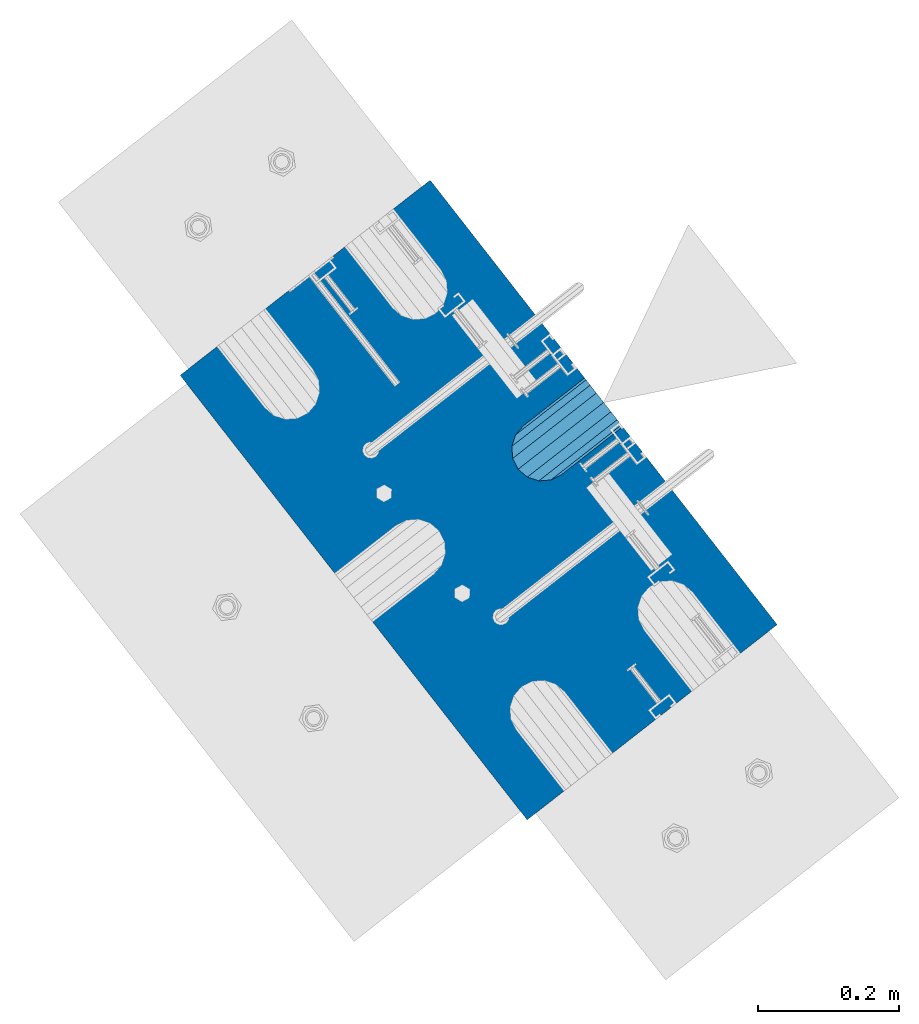
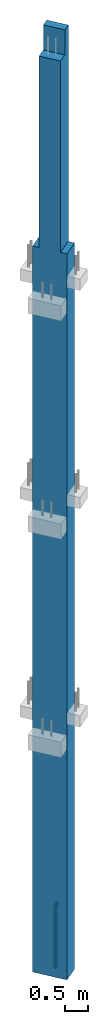
# One storey, part 2 of 42: 1 beam, 1 column, 2 elements without a shape of their own.
"""IFC2X3 building model written with IfcOpenShell, lengths in millimetres."""

import ifcopenshell
import ifcopenshell.guid

model = None  # the IFC model being written
_history = None  # IfcOwnerHistory: only IFC2X3 demands one
_inside = {}  # id of a spatial element -> (the spatial element, [elements in it])
_under = {}  # id of a project, library or spatial element -> (it, [spatial elements below it])
_declared = {}  # id of a project -> (the project, [libraries it declares])
_typed = {}  # id of a type object -> (the type object, [elements of that type])
_made_of = {}  # id of a material, layer set ... -> (it, [elements and type objects made of it])


def new_model(schema):
    """Start an empty IFC model of exactly this schema.

    Asked for "IFC4X3", IfcOpenShell would pick the latest addendum, in which some entities
    have other attributes; the version numbers below select the first issue.
    IFC2X3 requires an IfcOwnerHistory on every rooted entity: one is made here for all.
    """
    global model, _history
    if schema == "IFC4X3":
        model = ifcopenshell.file(schema_version=(4, 3, 0, 0))
    else:
        model = ifcopenshell.file(schema=schema)
    _inside.clear()
    _under.clear()
    _declared.clear()
    _typed.clear()
    _made_of.clear()
    _history = None
    if model.schema == "IFC2X3":
        org = make("IfcOrganization", Name="unknown")
        user = make(
            "IfcPersonAndOrganization",
            ThePerson=make("IfcPerson", FamilyName="unknown"),
            TheOrganization=org,
        )
        app = make(
            "IfcApplication",
            ApplicationDeveloper=org,
            Version="unknown",
            ApplicationFullName="unknown",
            ApplicationIdentifier="unknown",
        )
        _history = make(
            "IfcOwnerHistory",
            OwningUser=user,
            OwningApplication=app,
            ChangeAction="ADDED",
            CreationDate=0,
        )
    return model


def make(cls, **values):
    """One entity of the class cls with the attributes given. An attribute that is None is left unset."""
    return model.create_entity(
        cls, **{name: value for name, value in values.items() if value is not None}
    )


def rooted(cls, **values):
    """An entity with a GlobalId (a new one), such as an element, a storey or a relation."""
    return make(cls, GlobalId=ifcopenshell.guid.new(), OwnerHistory=_history, **values)


def si_unit(unit_type, name, prefix=None):
    """IfcSIUnit, for example si_unit("LENGTHUNIT", "METRE", prefix="MILLI")."""
    return make("IfcSIUnit", UnitType=unit_type, Prefix=prefix, Name=name)


def assignment(units):
    """IfcUnitAssignment: the units of a project."""
    return None if units is None else make("IfcUnitAssignment", Units=units)


def point(xyz):
    """IfcCartesianPoint."""
    return None if xyz is None else make("IfcCartesianPoint", Coordinates=xyz)


def direction(xyz):
    """IfcDirection."""
    return None if xyz is None else make("IfcDirection", DirectionRatios=xyz)


def frame(location, z_axis=None, x_axis=None):
    """IfcAxis2Placement3D, a coordinate frame: its origin and axes. An axis left out is left unset."""
    return make(
        "IfcAxis2Placement3D",
        Location=point(location),
        Axis=direction(z_axis),
        RefDirection=direction(x_axis),
    )


def origin_with_axes():
    """The frame at (0, 0, 0) with the z axis (0, 0, 1) and the x axis (1, 0, 0) written out."""
    return frame((0.0, 0.0, 0.0), z_axis=(0.0, 0.0, 1.0), x_axis=(1.0, 0.0, 0.0))


def place(relative_to, where):
    """IfcLocalPlacement: puts the frame where relative to a parent placement (None: the world)."""
    return make(
        "IfcLocalPlacement", PlacementRelTo=relative_to, RelativePlacement=where
    )


def context(
    kind, dimensions, precision=None, world=None, true_north=None, identifier=None
):
    """IfcGeometricRepresentationContext, for example the 3D "Model" context."""
    return make(
        "IfcGeometricRepresentationContext",
        ContextIdentifier=identifier,
        ContextType=kind,
        CoordinateSpaceDimension=dimensions,
        Precision=precision,
        WorldCoordinateSystem=world,
        TrueNorth=true_north,
    )


def subcontext(parent, identifier, kind, view, scale=None):
    """IfcGeometricRepresentationSubContext, for example "Body" below "Model"."""
    return make(
        "IfcGeometricRepresentationSubContext",
        ContextIdentifier=identifier,
        ContextType=kind,
        ParentContext=parent,
        TargetScale=scale,
        TargetView=view,
    )


def project(units=None, contexts=None):
    """IfcProject with its units and contexts."""
    return rooted(
        "IfcProject",
        Name="project",
        RepresentationContexts=contexts,
        UnitsInContext=assignment(units),
    )


def spatial(cls, under=None, at=None, **own):
    """A site, building, storey or space (cls), placed at a placement, below another one or the project."""
    s = rooted(cls, ObjectPlacement=at, **own)
    if under is not None:
        _under.setdefault(under.id(), (under, []))[1].append(s)
    return s


def faces_of(points, faces, orient=None, outer=None):
    """IfcFace entities. A face is a list of loops; a loop is a list of indices into points, from 0.

    orient and outer hold one flag for each loop. By default every Orientation is true, the
    first loop of a face is its IfcFaceOuterBound and the others are IfcFaceBound.
    """
    made = []
    for i, loops in enumerate(faces):
        bounds = []
        for j, loop in enumerate(loops):
            is_outer = j == 0 if outer is None else outer[i][j]
            bounds.append(
                make(
                    "IfcFaceOuterBound" if is_outer else "IfcFaceBound",
                    Bound=make("IfcPolyLoop", Polygon=[points[k] for k in loop]),
                    Orientation=True if orient is None else orient[i][j],
                )
            )
        made.append(make("IfcFace", Bounds=bounds))
    return made


def faceted_brep(points, faces, orient=None, outer=None, voids=None):
    """IfcFacetedBrep: a solid bounded by flat faces; with voids (closed shells), ...WithVoids."""
    shared = [point(p) for p in points]
    hull = make("IfcClosedShell", CfsFaces=faces_of(shared, faces, orient, outer))
    if voids is None:
        return make("IfcFacetedBrep", Outer=hull)
    return make(
        "IfcFacetedBrepWithVoids",
        Outer=hull,
        Voids=[
            make(cls, CfsFaces=faces_of(shared, fs, o, b)) for cls, fs, o, b in voids
        ],
    )


def shape(context_of_items, identifier, shape_type, items):
    """IfcShapeRepresentation: the items that make up one representation, for example the "Body"."""
    return make(
        "IfcShapeRepresentation",
        ContextOfItems=context_of_items,
        RepresentationIdentifier=identifier,
        RepresentationType=shape_type,
        Items=items,
    )


def material(Name=None, Category=None):
    """IfcMaterial."""
    return make("IfcMaterial", Name=Name, Category=Category)


def made_of(thing, what):
    """Note that an element or type object is made of a material, layer set ...; save() writes the relation."""
    if what is not None:
        _made_of.setdefault(what.id(), (what, []))[1].append(thing)
    return thing


def type_object(cls, material=None, **own):
    """A type object (cls), such as IfcWallType, which elements share."""
    return made_of(rooted(cls, **own), material)


def element(
    cls,
    number,
    at=None,
    inside=None,
    cuts=None,
    type_object=None,
    material=None,
    context=None,
    identifier="Body",
    shape_type=None,
    held_by="IfcProductDefinitionShape",
    body=None,
    shapes=None,
    **own,
):
    """One element of the class cls, such as IfcWall. Its Tag is "e" and its number.

    at: its placement. inside: the storey or other place that contains it. cuts: it is an
    opening in that element (IfcRelVoidsElement). A single representation is given by context,
    identifier, shape_type and body (its items); several are given by shapes. held_by: the class
    of the entity that holds the representations. save() writes the other relations.
    """
    e = rooted(cls, Tag="e%d" % number, ObjectPlacement=at, **own)
    if body is not None:
        shapes = [shape(context, identifier, shape_type, body)]
    if shapes is not None:
        e.Representation = make(held_by, Representations=shapes)
    if inside is not None:
        _inside.setdefault(inside.id(), (inside, []))[1].append(e)
    if cuts is not None:
        rooted(
            "IfcRelVoidsElement", RelatingBuildingElement=cuts, RelatedOpeningElement=e
        )
    if type_object is not None:
        _typed.setdefault(type_object.id(), (type_object, []))[1].append(e)
    return made_of(e, material)


def aggregate(whole, parts):
    """IfcRelAggregates: a whole, such as a stair, and the parts it consists of."""
    return rooted("IfcRelAggregates", RelatingObject=whole, RelatedObjects=parts)


def save(model, path):
    """Write the relations noted so far, then the file.

    IfcRelAggregates (storeys below a building ...), IfcRelContainedInSpatialStructure (elements
    in a storey), IfcRelDefinesByType, IfcRelAssociatesMaterial and IfcRelDeclares: one each for
    every whole, place, type object, material and project.
    """
    for whole, parts in _under.values():
        aggregate(whole, parts)
    for where, things in _inside.values():
        rooted(
            "IfcRelContainedInSpatialStructure",
            RelatedElements=things,
            RelatingStructure=where,
        )
    for kind, things in _typed.values():
        rooted("IfcRelDefinesByType", RelatedObjects=things, RelatingType=kind)
    for what, things in _made_of.values():
        rooted("IfcRelAssociatesMaterial", RelatedObjects=things, RelatingMaterial=what)
    for by, libraries in _declared.values():
        rooted("IfcRelDeclares", RelatingContext=by, RelatedDefinitions=libraries)
    model.write(path)


model = new_model("IFC2X3")

# Units and contexts
model_context = context("Model", 3, precision=1e-05, world=origin_with_axes())
body_context = subcontext(model_context, "Body", "Model", "MODEL_VIEW")
ifc_project = project(units=[si_unit("LENGTHUNIT", "METRE", prefix="MILLI"), si_unit("AREAUNIT", "SQUARE_METRE"), si_unit("VOLUMEUNIT", "CUBIC_METRE"), si_unit("MASSUNIT", "GRAM", prefix="KILO"), si_unit("TIMEUNIT", "SECOND"), si_unit("PLANEANGLEUNIT", "RADIAN"), si_unit("SOLIDANGLEUNIT", "STERADIAN"), si_unit("THERMODYNAMICTEMPERATUREUNIT", "DEGREE_CELSIUS"), si_unit("LUMINOUSINTENSITYUNIT", "LUMEN")], contexts=[model_context])

# Site, building, storey
site_placement = place(None, frame((171687.4, 84828.52, 14700.0), z_axis=(0.0, 0.0, 1.0), x_axis=(1.0, 0.0, 0.0)))
site = spatial("IfcSite", under=ifc_project, at=site_placement, CompositionType="ELEMENT")
building_placement = place(site_placement, origin_with_axes())
building = spatial("IfcBuilding", under=site, at=building_placement, Name="Undefined", CompositionType="ELEMENT")
storey_placement = place(building_placement, origin_with_axes())
storey = spatial("IfcBuildingStorey", under=building, at=storey_placement, Name="Undefined", CompositionType="ELEMENT", Elevation=0.0)

# Assemblies, column, beam
assembly_1_placement = place(storey_placement, origin_with_axes())
assembly_1 = element("IfcElementAssembly", 1, at=assembly_1_placement, inside=storey, AssemblyPlace="NOTDEFINED", PredefinedType="REINFORCEMENT_UNIT")
ifc_material_1 = material(Name="CONCRETE/C50/60")
column_type = type_object("IfcColumnType", PredefinedType="NOTDEFINED")
column_placement = place(assembly_1_placement, frame((18096.7856708698, 265349.288407257, -1290.0), z_axis=(-0.788225611989142, -0.615386370180835, 0.0), x_axis=(0.0, 0.0, 1.0)))
column = element("IfcColumn", 2, at=column_placement, type_object=column_type, material=ifc_material_1, context=body_context, shape_type="Brep", body=[
    faceted_brep([(24210.0, -250.000000288157, 225.00000024747), (24210.0, -250.000000288797, -24.9999997523264), (24210.0, 249.99999971097, -24.9999997548875), (24210.0, 249.999999711639, 225.000000244938), (24870.0, -250.000000288797, -24.9999997523264), (24870.0, 249.99999971097, -24.9999997548875), (19160.0, -400.000000288099, 225.000000248256), (19160.0, -400.000000289263, -224.999999751424), (19160.0, -250.000000289321, -224.999999752152), (19160.0, -250.000000288157, 225.00000024747), (0.0, -400.000000329339, 225.000000121712), (0.0, -400.000000330474, -224.999999877968), (0.0, 399.999999670341, 225.000000117609), (0.0, 399.999999669206, -224.999999882071), (19160.0, 399.999999711552, 225.000000244181), (19160.0, 399.999999710388, -224.999999755499), (19160.0, 249.999999711639, 225.000000244938), (19160.0, 249.999999710475, -224.999999754713), (24870.0, -250.000000289321, -224.999999752152), (24870.0, 249.999999710475, -224.999999754713)], [[[0, 1, 2, 3]], [[4, 5, 2, 1]], [[6, 7, 8, 9]], [[10, 11, 7, 6]], [[11, 10, 12, 13]], [[13, 12, 14, 15]], [[16, 17, 15, 14]], [[18, 8, 7, 11, 13, 15, 17, 19]], [[0, 9, 8, 18, 4, 1]], [[16, 14, 12, 10, 6, 9, 0, 3]], [[19, 17, 16, 3, 2, 5]], [[18, 19, 5, 4]]]),
])
assembly_2_placement = place(assembly_1_placement, origin_with_axes())
assembly_2 = element("IfcElementAssembly", 3, at=assembly_2_placement, AssemblyPlace="NOTDEFINED", PredefinedType="RIGID_FRAME")
aggregate(assembly_1, [assembly_2, column])
ifc_material_2 = material(Name="STEEL/NEG_BETON")
beam_type = type_object("IfcBeamType", PredefinedType="NOTDEFINED")
beam_placement = place(assembly_2_placement, frame((18187.4316162484, 265420.057839827, -1290.0), z_axis=(0.615386370178831, -0.788225611990706, 0.0), x_axis=(0.0, 0.0, 1.0)))
beam = element("IfcBeam", 4, at=beam_placement, type_object=beam_type, material=ifc_material_2, context=body_context, shape_type="Brep", body=[
    faceted_brep([(0.0, -43.999999753345, 2.88331648334861e-07), (0.0, -40.6506991838105, -16.8380707357428), (1590.0, -40.6506991838105, -16.8380707357428), (1589.99999999999, -43.999999753345, 2.88331648334861e-07), (0.0, -31.1126981254783, -31.1126980838017), (1590.0, -31.1126981254783, -31.1126980838017), (0.0, -16.8380707773322, -40.6506991419883), (1590.0, -16.8380707773322, -40.6506991419883), (0.0, 2.46742274612188e-07, -43.9999997114064), (1590.0, 2.46742274612188e-07, -43.9999997114064), (0.0, 16.8380712707876, -40.6506991418137), (1590.0, 16.8380712707876, -40.6506991418137), (0.0, 31.1126986189047, -31.1126980834524), (1590.0, 31.1126986189047, -31.1126980834524), (0.0, 40.6506996771204, -16.8380707352771), (1590.0, 40.6506996771204, -16.8380707352771), (0.0, 44.0000002465677, 2.88768205791712e-07), (1590.0, 44.0000002465677, 2.88768205791712e-07), (0.0, 40.6506996770622, 16.8380713128427), (1590.0, 40.6506996770622, 16.8380713128427), (0.0, 31.1126986187301, 31.1126986609306), (1590.0, 31.1126986187301, 31.1126986609306), (0.0, 16.8380712705839, 40.6506997191464), (1590.0, 16.8380712705839, 40.6506997191464), (0.0, 2.46509443968534e-07, 44.0000002885354), (1590.0, 2.46509443968534e-07, 44.0000002885354), (0.0, -16.8380707775359, 40.6506997189426), (1590.0, -16.8380707775359, 40.6506997189426), (0.0, -31.1126981256821, 31.1126986605814), (1590.0, -31.1126981256821, 31.1126986605814), (0.0, -40.6506991838978, 16.838071312377), (1590.0, -40.6506991838978, 16.838071312377), (4.47878846898675e-07, -40.0000000634464, 0.0), (4.47878846898675e-07, -36.9551813638827, 15.3073372946019), (1590.0, -36.9551810538396, 15.3073375829845), (1589.99999999999, -39.999999753345, 2.88360752165318e-07), (4.47937054559588e-07, -28.2842713108694, 28.284271247463), (1590.0, -28.2842710008845, 28.2842715359002), (4.4800981413573e-07, -15.3073373580119, 36.9551813004509), (1590.0, -15.3073370480561, 36.9551815889135), (4.48068021796644e-07, -6.34463503956795e-08, 40.0), (1590.0, 2.46538547798991e-07, 40.0000002885645), (4.48140781372786e-07, 15.3073372311774, 36.9551813004509), (1590.0, 15.3073375411332, 36.9551815890882), (4.48213540948927e-07, 28.2842711840058, 28.284271247463), (1590.0, 28.2842714939907, 28.2842715361621), (4.48271748609841e-07, 36.95518123699, 15.3073372946019), (1590.0, 36.9551815469749, 15.3073375833046), (4.48286300525069e-07, 39.9999999365536, 0.0), (1590.0, 40.0000002465677, 2.88768205791712e-07), (4.48271748609841e-07, 36.95518123699, -15.3073372946019), (1590.0, 36.9551815470913, -15.3073370058555), (4.48213540948927e-07, 28.2842711840058, -28.284271247463), (1590.0, 28.2842714941071, -28.2842709587712), (4.48140781372786e-07, 15.3073372311774, -36.9551813004509), (1590.0, 15.3073375413369, -36.9551810117846), (4.48068021796644e-07, -6.34463503956795e-08, -40.0), (1590.0, 2.46742274612188e-07, -39.9999997114064), (4.4800981413573e-07, -15.3073373580119, -36.9551813004509), (1590.0, -15.3073370479106, -36.9551810119592), (4.47937054559588e-07, -28.2842713108694, -28.284271247463), (1590.0, -28.284271000739, -28.2842709590332), (4.47878846898675e-07, -36.9551813638827, -15.3073372946019), (1590.0, -36.9551810537523, -15.3073370062048), (1591.55291427061, -44.204444795876, 2.88884621113539e-07), (1592.41977704577, -40.969268875866, 16.83807131293), (1594.88839337186, -31.7562673225475, 31.1126986611343), (1598.5829387913, -17.9680361063511, 40.6506997194665), (1602.94095225512, -1.70370843930868, 44.0000002890592), (1607.29896571893, 14.5606192276464, 40.650699719612), (1610.99351113838, 28.3488504439301, 31.1126986614254), (1613.46212746447, 37.5618519973068, 16.8380713133374), (1614.32899023963, 40.7970279174624, 2.89292074739933e-07), (1613.46212746447, 37.5618519973941, -16.8380707347824), (1610.99351113838, 28.3488504441048, -31.1126980829576), (1607.29896571893, 14.5606192278792, -40.650699141348), (1602.94095225512, -1.70370843910496, -43.9999997109117), (1598.5829387913, -17.9680361061473, -40.6506991414644), (1594.88839337186, -31.7562673223438, -31.1126980832487), (1592.41977704577, -40.9692688757787, -16.8380707351898), (1613.29371405922, 36.9333246122987, 2.89292074739933e-07), (1612.50565699089, 33.9922555939993, 15.3073375838285), (1610.26146033081, 25.6167996363656, 28.2842715366569), (1606.90278267677, 13.082043985225, 36.9551815895829), (1602.94095225512, -1.70370843933779, 40.0000002890883), (1598.97912183347, -16.4894608639006, 36.9551815894083), (1595.62044417943, -29.024216514983, 28.2842715363658), (1593.37624751934, -37.3996724725293, 15.3073375835083), (1592.58819045102, -40.3407414907415, 2.88913724943995e-07), (1593.37624751934, -37.3996724724711, -15.30733700571), (1595.62044417943, -29.0242165148375, -28.2842709585093), (1598.97912183347, -16.489460863726, -36.9551810114353), (1602.94095225512, -1.70370843910496, -39.9999997108825), (1606.90278267677, 13.0820439854288, -36.9551810112898), (1610.26146033081, 25.6167996365111, -28.2842709582183), (1612.50565699089, 33.9922555940866, -15.3073370053316), (1630.55634918609, 20.2456576060504, 31.1126986613672), (1635.32534971523, 28.5058088238875, 16.8380713132792), (1623.41903551202, 7.88346769296913, 40.6506997195829), (1614.99999999998, -6.6987295645813, 44.0000002890592), (1606.58096448795, -21.2809268221026, 40.6506997194665), (1599.44365081388, -33.6431167351257, 31.1126986611052), (1594.67465028474, -41.9032679528755, 16.83807131293), (1592.99999999999, -44.8038473309425, 2.88884621113539e-07), (1594.67465028474, -41.9032679528173, -16.8380707351898), (1599.44365081388, -33.6431167349801, -31.1126980832778), (1606.58096448795, -21.2809268218698, -40.6506991414935), (1614.99999999998, -6.69872956431936, -43.9999997108825), (1623.41903551202, 7.88346769317286, -40.6506991413771), (1630.55634918609, 20.245657606225, -31.1126980830159), (1635.32534971523, 28.5058088239748, -16.8380707348406), (1636.99999999998, 31.4063882019836, 2.89204763248563e-07), (1633.47759065021, 25.3053962432023, -15.307337005419), (1634.99999999998, 27.9422865869128, 2.89262970909476e-07), (1629.14213562371, 17.7961678634456, -28.2842709582474), (1622.65366864729, 6.55781339702662, -36.9551810113189), (1614.99999999998, -6.69872956431936, -39.9999997109117), (1607.34633135268, -19.9552725257818, -36.9551810114644), (1600.85786437626, -31.1936269922007, -28.2842709585384), (1596.52240934976, -38.7028553720447, -15.30733700571), (1594.99999999999, -41.3397457158135, 2.88884621113539e-07), (1596.52240934976, -38.7028553721029, 15.3073375835083), (1600.85786437626, -31.1936269923463, 28.2842715363658), (1607.34633135268, -19.9552725259855, 36.9551815894083), (1614.99999999998, -6.6987295645522, 40.0000002890592), (1622.65366864729, 6.5578133968811, 36.9551815895829), (1629.14213562371, 17.796167863271, 28.2842715366278), (1633.47759065021, 25.305396243115, 15.3073375837994), (1647.35533905931, 7.35533930556267, 31.1126986613381), (1654.09972428659, 14.0997245328326, 16.8380713131919), (1637.26165326253, -2.73834649124183, 40.6506997195538), (1625.35533905931, -14.6446606944664, 44.000000289001), (1613.4490248561, -26.5509748976619, 40.6506997194374), (1603.35533905931, -36.6446606944373, 31.1126986610761), (1596.61095383203, -43.3890459216491, 16.83807131293), (1594.24264068711, -45.7573590665124, 2.88855517283082e-07), (1596.61095383203, -43.3890459215909, -16.8380707352189), (1603.35533905931, -36.6446606942627, -31.1126980833069), (1613.4490248561, -26.5509748974582, -40.6506991415517), (1625.35533905931, -14.6446606942336, -43.9999997109699), (1637.26165326253, -2.7383464910381, -40.6506991414062), (1647.35533905931, 7.35533930567908, -31.1126980831032), (1654.09972428659, 14.099724532949, -16.8380707348988), (1656.46803743151, 16.4680376778415, 2.89175659418106e-07), (1651.48659835683, 11.4865986031655, -15.3073370054772), (1653.63961030677, 13.6396105530439, 2.89146555587649e-07), (1645.35533905931, 5.35533930567908, -28.2842709583347), (1636.17926106223, -3.82073869134183, -36.9551810113771), (1625.35533905931, -14.6446606942336, -39.9999997109699), (1614.53141705639, -25.4685826971836, -36.9551810114644), (1605.35533905931, -34.6446606942627, -28.2842709585675), (1599.22407976179, -40.7759199918073, -15.3073370057391), (1597.07106781185, -42.9289319418021, 2.88826413452625e-07), (1599.22407976179, -40.7759199918946, 15.3073375834792), (1605.35533905931, -34.6446606944082, 28.284271536395), (1614.53141705639, -25.4685826973582, 36.9551815894083), (1625.35533905931, -14.6446606944373, 40.000000289001), (1636.17926106223, -3.82073869154556, 36.9551815894956), (1645.35533905931, 5.35533930556267, 28.2842715365696), (1651.48659835683, 11.4865986031364, 15.3073375837412), (1660.24565735981, -9.44365056764218, 31.1126986612508), (1668.50580857761, -4.6746500384761, 16.8380713131337), (1647.88346744676, -16.5809642417589, 40.6506997194665), (1633.3012701892, -24.9999997537816, 44.0000002889428), (1618.71907293164, -33.4190352658043, 40.6506997193792), (1606.35688301859, -40.5563489398628, 31.112698661047), (1598.09673180079, -45.3253494689416, 16.8380713129009), (1595.19615242269, -46.9999997536361, 2.88855517283082e-07), (1598.09673180079, -45.3253494688834, -16.8380707352189), (1606.35688301859, -40.5563489396882, -31.112698083336), (1618.71907293164, -33.4190352655714, -40.6506991415517), (1633.3012701892, -24.9999997535488, -43.9999997110281), (1647.88346744676, -16.5809642415552, -40.6506991414644), (1660.24565735981, -9.44365056749666, -31.1126980831614), (1668.50580857761, -4.67465003841789, -16.8380707349861), (1671.40638795571, -2.99999975369428, 2.89088347926736e-07), (1665.30539599684, -6.52240910343244, -15.3073370055354), (1667.94228634057, -4.99999975372339, 2.89030140265822e-07), (1657.79616761703, -10.8578641298518, -28.2842709583929), (1646.55781315062, -17.3463311062951, -36.9551810114644), (1633.3012701892, -24.9999997535488, -39.999999710999), (1620.04472722778, -32.6536684008606, -36.9551810115227), (1608.80637276137, -39.142135377333, -28.2842709585675), (1601.29714438156, -43.4775904038397, -15.30733700571), (1598.66025403783, -44.9999997536652, 2.88826413452625e-07), (1601.29714438156, -43.4775904038979, 15.3073375834501), (1608.80637276137, -39.1421353774786, 28.2842715363076), (1620.04472722778, -32.6536684010644, 36.9551815893792), (1633.3012701892, -24.9999997537816, 40.0000002889428), (1646.55781315062, -17.3463311064697, 36.9551815894374), (1657.79616761703, -10.8578641300264, 28.2842715364823), (1665.30539599684, -6.52240910349065, 15.3073375836248), (1668.34885019768, -29.006488615385, 31.1126986611052), (1677.56185175105, -26.5378722892492, 16.8380713130173), (1654.56061898146, -32.7010340348643, 40.6506997193792), (1638.29629131443, -37.0590474986238, 44.0000002888846), (1622.0319636474, -41.4170609624416, 40.6506997193792), (1608.24373243118, -45.1116063818336, 31.1126986610761), (1599.03073087781, -47.5802227078821, 16.83807131293), (1595.79555495772, -48.4470854829997, 2.88855517283082e-07), (1599.03073087781, -47.5802227078239, -16.8380707351898), (1608.24373243118, -45.111606381688, -31.112698083336), (1622.0319636474, -41.4170609622379, -40.6506991415808), (1638.29629131443, -37.0590474984201, -43.9999997110572), (1654.56061898146, -32.7010340346314, -40.6506991415808), (1668.34885019768, -29.0064886152395, -31.1126980832778), (1677.56185175105, -26.5378722891619, -16.8380707351025), (1680.79702767114, -25.6710095140443, 2.88913724943995e-07), (1673.99225534772, -27.4943427627441, -15.3073370056518), (1676.93332436598, -26.7062856944685, 2.88942828774452e-07), (1665.61679939011, -29.7385394227749, -28.2842709585093), (1653.082043739, -33.0972170768073, -36.9551810115518), (1638.29629131443, -37.0590474984201, -39.9999997110572), (1623.51053888986, -41.020877920062, -36.9551810115518), (1610.97578323875, -44.3795555741235, -28.2842709585675), (1602.60032728114, -46.6237522342417, -15.3073370057391), (1599.65925826287, -47.4118093026336, 2.88826413452625e-07), (1602.60032728114, -46.623752234329, 15.3073375834501), (1610.97578323875, -44.379555574269, 28.2842715363076), (1623.51053888986, -41.0208779202658, 36.955181589321), (1638.29629131443, -37.0590474986238, 40.0000002889137), (1653.082043739, -33.0972170769819, 36.9551815893501), (1665.61679939011, -29.7385394229495, 28.2842715363658), (1673.99225534772, -27.4943427628314, 15.3073375835083), (1608.88730162777, -49.9999997535779, -31.1126980833942), (1599.34930056949, -49.999999753607, -16.838070735248), (1623.16192897591, -49.9999997535488, -40.6506991416682), (1639.99999999997, -49.9999997535488, -43.9999997111445), (1656.83807102403, -49.9999997535488, -40.6506991416682), (1671.11269837217, -49.9999997535779, -31.1126980833942), (1680.65069943045, -49.999999753607, -16.838070735248), (1683.99999999996, -49.9999997536361, 2.88826413452625e-07), (1680.65069943045, -49.9999997536943, 16.8380713128718), (1671.11269837217, -49.9999997537234, 31.1126986609888), (1656.83807102403, -49.9999997537525, 40.650699719321), (1639.99999999997, -49.9999997537816, 44.0000002887973), (1623.16192897591, -49.9999997537525, 40.650699719321), (1608.88730162777, -49.9999997536943, 31.112698661047), (1599.34930056949, -49.9999997536943, 16.8380713128718), (1596.0, -49.9999997536361, 2.88826413452625e-07), (1676.95518130041, -49.9999997535779, -15.3073370057391), (1679.99999999996, -49.9999997536361, 2.88826413452625e-07), (1668.28427124742, -49.9999997535488, -28.2842709585966), (1655.30733729457, -49.9999997535488, -36.9551810116391), (1639.99999999997, -49.9999997535197, -39.9999997111445), (1624.69266270537, -49.9999997535488, -36.9551810116391), (1611.71572875252, -49.9999997535488, -28.2842709585966), (1603.04481869953, -49.9999997535779, -15.3073370057391), (1600.0, -49.9999997536361, 2.88826413452625e-07), (1603.04481869953, -49.9999997536943, 15.307337583421), (1611.71572875252, -49.9999997537234, 28.2842715362785), (1624.69266270537, -49.9999997537525, 36.9551815892628), (1639.99999999997, -49.9999997537525, 40.0000002888264), (1655.30733729457, -49.9999997537525, 36.9551815892628), (1668.28427124742, -49.9999997537234, 28.2842715362785), (1676.95518130041, -49.9999997536943, 15.307337583421), (1599.3493005695, -109.999999753578, -16.8380707355391), (1596.0, -109.999999753607, 2.88506271317601e-07), (1608.88730162779, -109.999999753549, -31.1126980836852), (1623.16192897594, -109.999999753491, -40.6506991419592), (1640.0, -109.999999753491, -43.9999997114646), (1656.83807102406, -109.999999753491, -40.6506991419592), (1671.11269837221, -109.999999753549, -31.1126980836852), (1680.6506994305, -109.999999753578, -16.8380707355391), (1684.0, -109.999999753607, 2.88506271317601e-07), (1680.6506994305, -109.999999753636, 16.8380713125807), (1671.11269837221, -109.999999753694, 31.1126986607269), (1656.83807102406, -109.999999753723, 40.6506997190008), (1640.0, -109.999999753723, 44.0000002885063), (1623.16192897594, -109.999999753723, 40.6506997190008), (1608.88730162779, -109.999999753694, 31.1126986607269), (1599.3493005695, -109.999999753636, 16.8380713125807), (1603.04481869955, -109.999999753636, 15.3073375831009), (1600.0, -109.999999753607, 2.88506271317601e-07), (1611.71572875254, -109.999999753665, 28.2842715359584), (1624.6926627054, -109.999999753665, 36.9551815889718), (1640.0, -109.999999753694, 40.0000002884772), (1655.3073372946, -109.999999753665, 36.9551815889718), (1668.28427124746, -109.999999753665, 28.2842715359584), (1676.95518130045, -109.999999753636, 15.3073375831009), (1680.0, -109.999999753607, 2.88506271317601e-07), (1676.95518130045, -109.999999753578, -15.3073370060883), (1668.28427124746, -109.999999753549, -28.2842709589167), (1655.3073372946, -109.99999975352, -36.955181011901), (1640.0, -109.99999975352, -39.9999997114646), (1624.6926627054, -109.99999975352, -36.955181011901), (1611.71572875254, -109.999999753549, -28.2842709589167), (1603.04481869955, -109.999999753578, -15.3073370060883)], [[[0, 1, 2, 3]], [[1, 4, 5, 2]], [[4, 6, 7, 5]], [[6, 8, 9, 7]], [[8, 10, 11, 9]], [[10, 12, 13, 11]], [[12, 14, 15, 13]], [[14, 16, 17, 15]], [[16, 18, 19, 17]], [[18, 20, 21, 19]], [[20, 22, 23, 21]], [[22, 24, 25, 23]], [[24, 26, 27, 25]], [[26, 28, 29, 27]], [[28, 30, 31, 29]], [[30, 0, 3, 31]], [[32, 33, 34, 35]], [[33, 36, 37, 34]], [[36, 38, 39, 37]], [[38, 40, 41, 39]], [[40, 42, 43, 41]], [[42, 44, 45, 43]], [[44, 46, 47, 45]], [[46, 48, 49, 47]], [[48, 50, 51, 49]], [[50, 52, 53, 51]], [[52, 54, 55, 53]], [[54, 56, 57, 55]], [[56, 58, 59, 57]], [[58, 60, 61, 59]], [[60, 62, 63, 61]], [[62, 32, 35, 63]], [[30, 28, 26, 24, 22, 20, 18, 16, 14, 12, 10, 8, 6, 4, 1, 0], [62, 60, 58, 56, 54, 52, 50, 48, 46, 44, 42, 40, 38, 36, 33, 32]], [[31, 3, 64, 65]], [[29, 31, 65, 66]], [[27, 29, 66, 67]], [[25, 27, 67, 68]], [[23, 25, 68, 69]], [[21, 23, 69, 70]], [[19, 21, 70, 71]], [[17, 19, 71, 72]], [[15, 17, 72, 73]], [[13, 15, 73, 74]], [[11, 13, 74, 75]], [[9, 11, 75, 76]], [[7, 9, 76, 77]], [[5, 7, 77, 78]], [[2, 5, 78, 79]], [[3, 2, 79, 64]], [[47, 49, 80, 81]], [[45, 47, 81, 82]], [[43, 45, 82, 83]], [[41, 43, 83, 84]], [[39, 41, 84, 85]], [[37, 39, 85, 86]], [[34, 37, 86, 87]], [[35, 34, 87, 88]], [[63, 35, 88, 89]], [[61, 63, 89, 90]], [[59, 61, 90, 91]], [[57, 59, 91, 92]], [[55, 57, 92, 93]], [[53, 55, 93, 94]], [[51, 53, 94, 95]], [[49, 51, 95, 80]], [[70, 96, 97, 71]], [[69, 98, 96, 70]], [[68, 99, 98, 69]], [[67, 100, 99, 68]], [[66, 101, 100, 67]], [[65, 102, 101, 66]], [[64, 103, 102, 65]], [[79, 104, 103, 64]], [[78, 105, 104, 79]], [[77, 106, 105, 78]], [[76, 107, 106, 77]], [[75, 108, 107, 76]], [[74, 109, 108, 75]], [[73, 110, 109, 74]], [[72, 111, 110, 73]], [[71, 97, 111, 72]], [[95, 112, 113, 80]], [[94, 114, 112, 95]], [[93, 115, 114, 94]], [[92, 116, 115, 93]], [[91, 117, 116, 92]], [[90, 118, 117, 91]], [[89, 119, 118, 90]], [[88, 120, 119, 89]], [[87, 121, 120, 88]], [[86, 122, 121, 87]], [[85, 123, 122, 86]], [[84, 124, 123, 85]], [[83, 125, 124, 84]], [[82, 126, 125, 83]], [[81, 127, 126, 82]], [[80, 113, 127, 81]], [[96, 128, 129, 97]], [[98, 130, 128, 96]], [[99, 131, 130, 98]], [[100, 132, 131, 99]], [[101, 133, 132, 100]], [[102, 134, 133, 101]], [[103, 135, 134, 102]], [[104, 136, 135, 103]], [[105, 137, 136, 104]], [[106, 138, 137, 105]], [[107, 139, 138, 106]], [[108, 140, 139, 107]], [[109, 141, 140, 108]], [[110, 142, 141, 109]], [[111, 143, 142, 110]], [[97, 129, 143, 111]], [[112, 144, 145, 113]], [[114, 146, 144, 112]], [[115, 147, 146, 114]], [[116, 148, 147, 115]], [[117, 149, 148, 116]], [[118, 150, 149, 117]], [[119, 151, 150, 118]], [[120, 152, 151, 119]], [[121, 153, 152, 120]], [[122, 154, 153, 121]], [[123, 155, 154, 122]], [[124, 156, 155, 123]], [[125, 157, 156, 124]], [[126, 158, 157, 125]], [[127, 159, 158, 126]], [[113, 145, 159, 127]], [[128, 160, 161, 129]], [[130, 162, 160, 128]], [[131, 163, 162, 130]], [[132, 164, 163, 131]], [[133, 165, 164, 132]], [[134, 166, 165, 133]], [[135, 167, 166, 134]], [[136, 168, 167, 135]], [[137, 169, 168, 136]], [[138, 170, 169, 137]], [[139, 171, 170, 138]], [[140, 172, 171, 139]], [[141, 173, 172, 140]], [[142, 174, 173, 141]], [[143, 175, 174, 142]], [[129, 161, 175, 143]], [[144, 176, 177, 145]], [[146, 178, 176, 144]], [[147, 179, 178, 146]], [[148, 180, 179, 147]], [[149, 181, 180, 148]], [[150, 182, 181, 149]], [[151, 183, 182, 150]], [[152, 184, 183, 151]], [[153, 185, 184, 152]], [[154, 186, 185, 153]], [[155, 187, 186, 154]], [[156, 188, 187, 155]], [[157, 189, 188, 156]], [[158, 190, 189, 157]], [[159, 191, 190, 158]], [[145, 177, 191, 159]], [[160, 192, 193, 161]], [[162, 194, 192, 160]], [[163, 195, 194, 162]], [[164, 196, 195, 163]], [[165, 197, 196, 164]], [[166, 198, 197, 165]], [[167, 199, 198, 166]], [[168, 200, 199, 167]], [[169, 201, 200, 168]], [[170, 202, 201, 169]], [[171, 203, 202, 170]], [[172, 204, 203, 171]], [[173, 205, 204, 172]], [[174, 206, 205, 173]], [[175, 207, 206, 174]], [[161, 193, 207, 175]], [[176, 208, 209, 177]], [[178, 210, 208, 176]], [[179, 211, 210, 178]], [[180, 212, 211, 179]], [[181, 213, 212, 180]], [[182, 214, 213, 181]], [[183, 215, 214, 182]], [[184, 216, 215, 183]], [[185, 217, 216, 184]], [[186, 218, 217, 185]], [[187, 219, 218, 186]], [[188, 220, 219, 187]], [[189, 221, 220, 188]], [[190, 222, 221, 189]], [[191, 223, 222, 190]], [[177, 209, 223, 191]], [[201, 224, 225, 200]], [[202, 226, 224, 201]], [[203, 227, 226, 202]], [[204, 228, 227, 203]], [[205, 229, 228, 204]], [[206, 230, 229, 205]], [[207, 231, 230, 206]], [[193, 232, 231, 207]], [[192, 233, 232, 193]], [[194, 234, 233, 192]], [[195, 235, 234, 194]], [[196, 236, 235, 195]], [[197, 237, 236, 196]], [[198, 238, 237, 197]], [[199, 239, 238, 198]], [[200, 225, 239, 199]], [[208, 240, 241, 209]], [[210, 242, 240, 208]], [[211, 243, 242, 210]], [[212, 244, 243, 211]], [[213, 245, 244, 212]], [[214, 246, 245, 213]], [[215, 247, 246, 214]], [[216, 248, 247, 215]], [[217, 249, 248, 216]], [[218, 250, 249, 217]], [[219, 251, 250, 218]], [[220, 252, 251, 219]], [[221, 253, 252, 220]], [[222, 254, 253, 221]], [[223, 255, 254, 222]], [[209, 241, 255, 223]], [[239, 225, 256, 257]], [[225, 224, 258, 256]], [[224, 226, 259, 258]], [[226, 227, 260, 259]], [[227, 228, 261, 260]], [[228, 229, 262, 261]], [[229, 230, 263, 262]], [[230, 231, 264, 263]], [[231, 232, 265, 264]], [[232, 233, 266, 265]], [[233, 234, 267, 266]], [[234, 235, 268, 267]], [[235, 236, 269, 268]], [[236, 237, 270, 269]], [[237, 238, 271, 270]], [[238, 239, 257, 271]], [[248, 249, 272, 273]], [[249, 250, 274, 272]], [[250, 251, 275, 274]], [[251, 252, 276, 275]], [[252, 253, 277, 276]], [[253, 254, 278, 277]], [[254, 255, 279, 278]], [[255, 241, 280, 279]], [[241, 240, 281, 280]], [[240, 242, 282, 281]], [[242, 243, 283, 282]], [[243, 244, 284, 283]], [[244, 245, 285, 284]], [[245, 246, 286, 285]], [[246, 247, 287, 286]], [[247, 248, 273, 287]], [[258, 259, 260, 261, 262, 263, 264, 265, 266, 267, 268, 269, 270, 271, 257, 256], [274, 275, 276, 277, 278, 279, 280, 281, 282, 283, 284, 285, 286, 287, 273, 272]]]),
])
aggregate(assembly_2, [beam])

save(model, "model.ifc")
